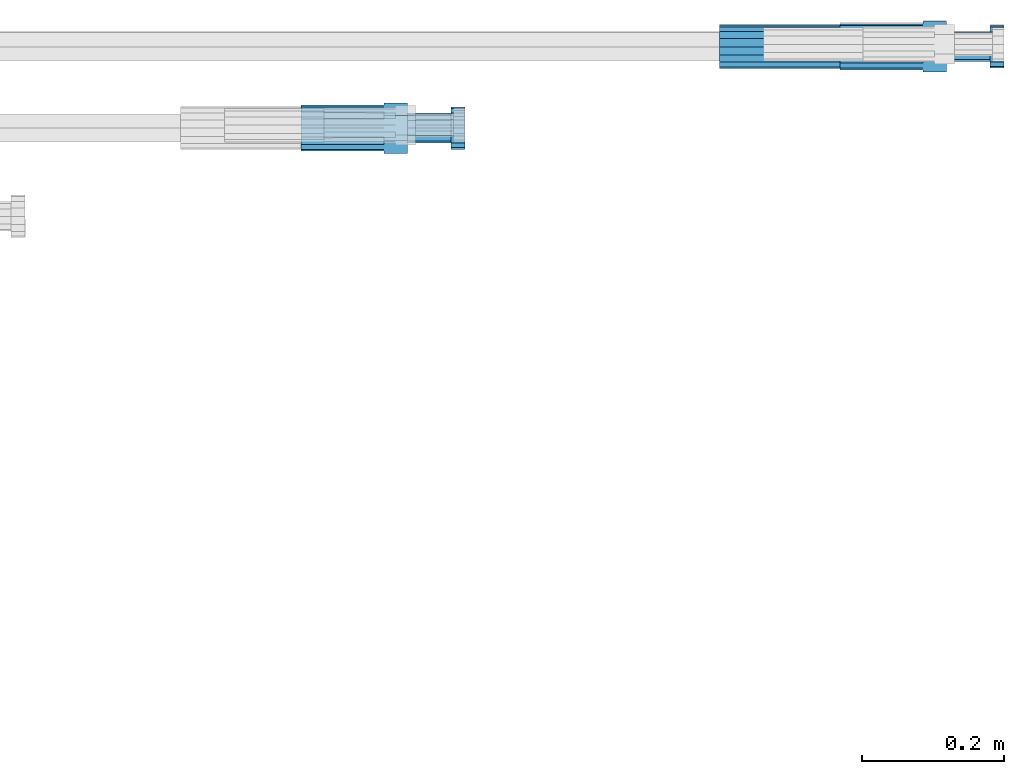
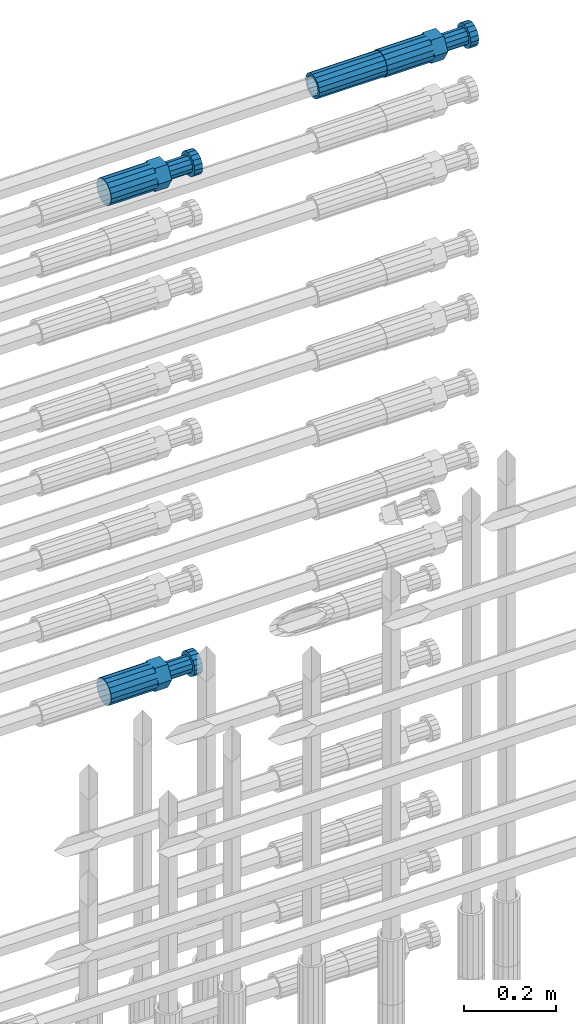
# One storey, part 114 of 119: 4 beams.
"""IFC2X3 building model written with IfcOpenShell, lengths in millimetres."""

from ifc_helpers import new_model, si_unit, frame, origin_with_axes, place, context, subcontext, project, spatial, faceted_brep, material, type_object, element, save


model = new_model("IFC2X3")

# Units and contexts
model_context = context("Model", 3, precision=1e-05, world=origin_with_axes())
body_context = subcontext(model_context, "Body", "Model", "MODEL_VIEW")
ifc_project = project(units=[si_unit("LENGTHUNIT", "METRE", prefix="MILLI"), si_unit("AREAUNIT", "SQUARE_METRE"), si_unit("VOLUMEUNIT", "CUBIC_METRE"), si_unit("MASSUNIT", "GRAM", prefix="KILO"), si_unit("TIMEUNIT", "SECOND"), si_unit("PLANEANGLEUNIT", "RADIAN"), si_unit("SOLIDANGLEUNIT", "STERADIAN"), si_unit("THERMODYNAMICTEMPERATUREUNIT", "DEGREE_CELSIUS"), si_unit("LUMINOUSINTENSITYUNIT", "LUMEN")], contexts=[model_context])

# Site, building, storey
site_placement = place(None, origin_with_axes())
site = spatial("IfcSite", under=ifc_project, at=site_placement, CompositionType="ELEMENT")
building_placement = place(site_placement, origin_with_axes())
building = spatial("IfcBuilding", under=site, at=building_placement, Name="Undefined", CompositionType="ELEMENT")
storey_placement = place(building_placement, origin_with_axes())
storey = spatial("IfcBuildingStorey", under=building, at=storey_placement, Name="Undefined", CompositionType="ELEMENT", Elevation=0.0)

# Beams
ifc_material = material(Name="STEEL/S275")
beam_type_1 = type_object("IfcBeamType", PredefinedType="NOTDEFINED")
beam_1_placement = place(storey_placement, frame((2039349.03023304, 6206399.98994599, 22359.9894122711), z_axis=(0.0, 0.0, 1.0), x_axis=(1.0, 0.0, 0.0)))
element("IfcBeam", 1, at=beam_1_placement, inside=storey, type_object=beam_type_1, material=ifc_material, Name="AG40N", context=body_context, shape_type="Brep", body=[
    faceted_brep([(1.62981450557709e-09, -23.4999999990687, 0.0), (7.45058059692383e-09, -21.7111690142192, 8.99306066057534), (170.000002125278, -21.711168999318, 8.99306066022245), (170.000002127141, -23.4999999844003, -3.66071617463604e-10), (4.65661287307739e-09, -16.6170093587134, 16.6170093578889), (170.000002122484, -16.6170093440451, 16.6170093575288), (1.86264514923096e-09, -8.99306066217832, 21.7111690140277), (170.000002118759, -8.99306064750999, 21.7111690136603), (2.3283064365387e-10, 9.31322574615479e-10, 23.5), (170.000002114102, 1.28056854009628e-08, 23.4999999996485), (-6.51925802230835e-09, 8.99306065868586, 21.7111690140241), (170.00000211224, 8.99306067335419, 21.7111690136639), (-7.45058059692383e-09, 16.6170093561523, 16.6170093578853), (170.000002109446, 16.6170093708206, 16.6170093575324), (-9.31322574615479e-09, 21.711169013055, 8.99306066057534), (170.000002108514, 21.7111690277234, 8.99306066022245), (-1.16415321826935e-09, 23.5000000009313, 0.0), (170.000002108514, 23.5000000144355, -3.66071617463604e-10), (-8.38190317153931e-09, 21.7111690151505, -8.99306066059444), (170.000002110377, 21.7111690300517, -8.9930606609546), (-5.58793544769287e-09, 16.6170093598776, -16.6170093579008), (170.000002113171, 16.6170093745459, -16.6170093582609), (-9.31322574615479e-10, 8.99306066334248, -21.7111690140396), (170.000002115965, 8.99306067801081, -21.7111690143961), (2.3283064365387e-10, 9.31322574615479e-10, -23.5), (170.00000211969, 1.7927959561348e-08, -23.5000000003843), (5.58793544769287e-09, -8.99306065752171, -21.7111690140396), (170.000002123415, -8.99306064285338, -21.7111690143961), (8.38190317153931e-09, -16.6170093549881, -16.6170093579008), (170.000002125278, -16.6170093403198, -16.6170093582646), (9.31322574615479e-09, -21.7111690121237, -8.99306066059444), (170.000002127141, -21.7111689972226, -8.9930606609546), (1.11758708953857e-08, -30.4999999990687, -9.54969436861575e-12), (1.30385160446167e-08, -28.1783257392235, -11.6718446871514), (170.000002129003, -28.1783257243223, -11.6718446875116), (170.000002129935, -30.4999999841675, -3.66071617463604e-10), (1.02445483207703e-08, -21.5667568228673, -21.5667568262129), (170.000002128072, -21.566756808199, -21.5667568265694), (7.45058059692383e-09, -11.6718446831219, -28.1783257416196), (170.000002125278, -11.6718446684536, -28.1783257419834), (3.72529029846191e-09, 3.95812094211578e-09, -30.5000000000277), (170.00000211969, 1.83936208486557e-08, -30.5000000003879), (-9.31322574615479e-10, 11.6718446905725, -28.1783257416232), (170.000002115965, 11.6718447052408, -28.1783257419797), (-6.51925802230835e-09, 21.5667568286881, -21.5667568262093), (170.000002110377, 21.5667568433564, -21.5667568265694), (-9.31322574615479e-09, 28.178325742716, -11.6718446871478), (170.000002108514, 28.1783257573843, -11.6718446875079), (-1.21071934700012e-08, 30.5, -5.91171556152403e-12), (170.000002106652, 30.5000000144355, -3.62433638656512e-10), (-1.21071934700012e-08, 28.1783257401548, 11.6718446871359), (170.00000210572, 28.1783257548232, 11.6718446867794), (-1.02445483207703e-08, 21.5667568240315, 21.5667568261974), (170.000002107583, 21.566756838467, 21.5667568258409), (-7.45058059692383e-09, 11.671844684286, 28.1783257416041), (170.000002110377, 11.6718446989544, 28.178325741244), (-2.79396772384644e-09, -2.56113708019257e-09, 30.5000000000159), (170.000002114102, 1.18743628263474e-08, 30.4999999996558), (1.86264514923096e-09, -11.6718446896411, 28.1783257416114), (170.000002118759, -11.67184467474, 28.178325741244), (7.45058059692383e-09, -21.5667568275239, 21.5667568261974), (170.000002123415, -21.5667568126228, 21.5667568258373), (1.02445483207703e-08, -28.1783257415518, 11.6718446871359), (170.000002127141, -28.1783257271163, 11.6718446867794)], [[[0, 1, 2, 3]], [[1, 4, 5, 2]], [[4, 6, 7, 5]], [[6, 8, 9, 7]], [[8, 10, 11, 9]], [[10, 12, 13, 11]], [[12, 14, 15, 13]], [[14, 16, 17, 15]], [[16, 18, 19, 17]], [[18, 20, 21, 19]], [[20, 22, 23, 21]], [[22, 24, 25, 23]], [[24, 26, 27, 25]], [[26, 28, 29, 27]], [[28, 30, 31, 29]], [[30, 0, 3, 31]], [[32, 33, 34, 35]], [[33, 36, 37, 34]], [[36, 38, 39, 37]], [[38, 40, 41, 39]], [[40, 42, 43, 41]], [[42, 44, 45, 43]], [[44, 46, 47, 45]], [[46, 48, 49, 47]], [[48, 50, 51, 49]], [[50, 52, 53, 51]], [[52, 54, 55, 53]], [[54, 56, 57, 55]], [[56, 58, 59, 57]], [[58, 60, 61, 59]], [[60, 62, 63, 61]], [[62, 32, 35, 63]], [[37, 39, 41, 43, 45, 47, 49, 51, 53, 55, 57, 59, 61, 63, 35, 34], [5, 7, 9, 11, 13, 15, 17, 19, 21, 23, 25, 27, 29, 31, 3, 2]], [[62, 60, 58, 56, 54, 52, 50, 48, 46, 44, 42, 40, 38, 36, 33, 32], [30, 28, 26, 24, 22, 20, 18, 16, 14, 12, 10, 8, 6, 4, 1, 0]]]),
])
beam_type_2 = type_object("IfcBeamType", Name="ROD65", PredefinedType="NOTDEFINED")
beam_2_placement = place(storey_placement, frame((2038759.02023304, 6206285.48994599, 21026.9894209215), z_axis=(0.0, 0.0, 1.0), x_axis=(1.0, 0.0, 0.0)))
element("IfcBeam", 2, at=beam_2_placement, inside=storey, type_object=beam_type_2, material=ifc_material, Name="AGB40", ObjectType="ROD65", context=body_context, shape_type="Brep", body=[
    faceted_brep([(116.999999999069, 17.8249999252148, 30.8738056446964), (116.999999998137, 22.0056957420893, 23.632628078838), (116.999999999069, 12.4372115600854, 30.0260848066173), (116.999999999069, 8.17543111252598, 30.8738056446964), (117.000000000931, -17.8250000746921, 30.8738056446964), (150.200000001118, -17.8250000723638, 30.8738056446964), (150.199999999255, 17.8249999275431, 30.8738056446964), (117.000000000931, -8.17543109622784, 30.8738056446964), (117.000000001863, -22.0056959956419, 23.6326278985034), (117.000000000931, -12.4372115437873, 30.0260848066173), (117.000000001863, -35.6500000746455, -2.18278728425503e-10), (150.200000002049, -35.6500000723172, -2.18278728425503e-10), (117.000000001863, -30.8443149488885, 8.32369080289209), (117.000000001863, -30.8443149488885, -8.32369080355784), (117.000000002794, -32.4999999918509, 0.0), (117.000000000931, -17.8250000746921, -30.873805645133), (150.200000001118, -17.8250000723638, -30.873805645133), (117.000000001863, -22.0056959961075, -23.6326278982269), (117.000000000931, -8.17543109389953, -30.873805645133), (117.000000000931, -12.4372115437873, -30.0260848066173), (116.999999999069, 17.8249999252148, -30.873805645133), (150.199999999255, 17.8249999275431, -30.873805645133), (116.999999999069, 8.17543111019768, -30.873805645133), (116.999999999069, 12.4372115600854, -30.0260848066173), (116.999999998137, 22.005695742555, -23.6326280785652), (116.999999998137, 35.6499999251682, -2.18278728425503e-10), (150.199999998324, 35.6499999277294, -2.18278728425503e-10), (116.999999998137, 30.8443150522653, -8.32369036550881), (116.999999997206, 32.5000000081491, 0.0), (116.999999998137, 30.8443150522653, 8.32369036483942), (1.86264514923096e-09, -22.9809703885112, 22.9809703885621), (1.86264514923096e-09, -30.0260848065373, 12.4372115518672), (117.000000001863, -30.0260847983882, 12.4372115518672), (117.000000001863, -22.9809703803621, 22.9809703885621), (-1.86264514923096e-09, 22.9809703885112, -22.9809703885621), (-1.86264514923096e-09, 30.0260848065373, -12.4372115518672), (116.999999998137, 30.0260848146863, -12.4372115518672), (116.999999998137, 22.9809703966603, -22.9809703885621), (1.86264514923096e-09, -30.0260848065373, -12.4372115518672), (1.86264514923096e-09, -22.9809703885112, -22.9809703885621), (117.000000001863, -22.9809703803621, -22.9809703885621), (117.000000001863, -30.0260847983882, -12.4372115518672), (9.31322574615479e-10, -12.4372115519363, 30.0260848066173), (0.0, 0.0, 32.5), (-9.31322574615479e-10, 12.4372115519363, 30.0260848066173), (-1.86264514923096e-09, 22.9809703885112, 22.9809703885621), (-1.86264514923096e-09, 30.0260848065373, 12.4372115518672), (-2.79396772384644e-09, 32.5, 0.0), (-9.31322574615479e-10, 12.4372115519363, -30.0260848066173), (0.0, 0.0, -32.5), (9.31322574615479e-10, -12.4372115519363, -30.0260848066173), (2.79396772384644e-09, -32.5, 0.0), (116.999999998137, 22.9809703966603, 22.9809703885621), (116.999999998137, 30.0260848146863, 12.4372115518672), (117.0, 8.14907252788544e-09, -32.5), (117.0, 8.14907252788544e-09, 32.5), (150.200000000186, -10.5000000959262, 18.1865334791873), (150.199999999255, -9.59262251853943e-08, 20.9999999997126), (150.199999998324, 10.4999999040738, 18.1865334791873), (150.199999997392, 18.1865333835594, 10.4999999997126), (150.199999997392, 20.9999999040738, -2.87400325760245e-10), (150.199999997392, 18.1865333835594, -10.5000000002874), (150.199999998324, 10.4999999040738, -18.1865334797621), (150.199999999255, -9.59262251853943e-08, -21.0000000002874), (150.200000000186, -10.5000000959262, -18.1865334797621), (150.200000000186, -18.1865335754119, -10.5000000002874), (150.200000001118, -21.0000000959262, -2.87400325760245e-10), (150.200000000186, -18.1865335754119, 10.4999999997126), (210.979999999516, 10.4999999082647, 18.1865334791873), (210.979999999516, -9.17352735996246e-08, 20.9999999997126), (210.979999997653, 18.1865333877504, 10.4999999997126), (210.979999997653, 20.9999999082647, -2.87400325760245e-10), (210.979999997653, 18.1865333877504, -10.5000000002874), (210.979999999516, 10.4999999082647, -18.1865334797621), (210.979999999516, -9.17352735996246e-08, -21.0000000002874), (210.979999999516, -10.5000000917353, -18.1865334797621), (210.980000000447, -18.1865335712209, -10.5000000002874), (210.980000001378, -21.0000000917353, -2.87400325760245e-10), (210.980000000447, -18.1865335712209, 10.4999999997126), (210.979999999516, -10.5000000917353, 18.1865334791873), (211.001368402503, -27.7269939335529, -11.4911163272045), (211.003082515672, -21.2238095656503, -21.2238154190527), (231.002518340945, -21.2131946226582, -21.2132004554769), (231.000804228708, -27.7163789905608, -11.4805013636287), (211.001368415542, -11.4911086384673, -27.7269970399575), (231.000804241747, -11.4804936954752, -27.7163820763781), (210.996487061493, -0.0106066407170147, -30.0106107396168), (230.995922887698, 8.30227509140968e-06, -29.999995776041), (210.98918159306, 11.4698940692469, -27.7269970332745), (230.988617419265, 11.4805090120062, -27.7163820696951), (210.980564201251, 21.2025913291145, -21.2238154067054), (230.980000027455, 21.2132062721066, -21.2132004431296), (210.971946807578, 27.7057702087332, -11.4911163110701), (230.971382633783, 27.7163851517253, -11.4805013474943), (210.964641331695, 29.9893806746695, -0.0106149565435771), (230.9640771579, 29.9999956176616, 7.03221303410828e-09), (210.959759964608, 27.7057637346443, 11.4698863966551), (230.959195790812, 27.7163786776364, 11.4805013602345), (210.958045851439, 21.2025793667417, 21.2025854885032), (230.957481677644, 21.2131943097338, 21.2132004520827), (210.959759951569, 11.4698784395587, 27.705767109408), (230.959195776843, 11.4804933823179, 27.7163820729838), (210.964641305618, -0.0106235581915826, 29.9893808090674), (230.964077131823, -8.61519947648048e-06, 29.9999957726432), (210.971946774051, -11.4911242681555, 27.7057671027251), (230.971382599324, -11.4805093251634, 27.7163820663009), (210.98056416586, -21.2238215280231, 21.2025854761559), (230.979999991134, -21.2132065852638, 21.2132004397354), (210.989181559533, -27.7270004076418, 11.4698863805206), (230.988617384806, -27.7163854646496, 11.4805013441), (210.996487035416, -30.0106108735781, -0.0106149740058754), (230.995922861621, -29.999995930586, -1.04300852399319e-08)], [[[0, 1, 2, 3]], [[4, 5, 6, 0, 3, 7]], [[8, 4, 7, 9]], [[10, 11, 5, 4, 8, 12]], [[13, 10, 12, 14]], [[15, 16, 11, 10, 13, 17]], [[18, 15, 17, 19]], [[20, 21, 16, 15, 18, 22]], [[20, 22, 23, 24]], [[25, 26, 21, 20, 24, 27]], [[25, 27, 28, 29]], [[30, 31, 32, 33]], [[34, 35, 36, 37]], [[38, 39, 40, 41]], [[31, 30, 42, 43, 44, 45, 46, 47, 35, 34, 48, 49, 50, 39, 38, 51]], [[46, 45, 52, 53]], [[28, 47, 46, 53, 29]], [[27, 36, 35, 47, 28]], [[24, 37, 36, 27]], [[23, 48, 34, 37, 24]], [[22, 54, 49, 48, 23]], [[18, 54, 22]], [[19, 50, 49, 54, 18]], [[17, 40, 39, 50, 19]], [[13, 41, 40, 17]], [[14, 51, 38, 41, 13]], [[12, 32, 31, 51, 14]], [[8, 33, 32, 12]], [[9, 42, 30, 33, 8]], [[7, 55, 43, 42, 9]], [[3, 55, 7]], [[2, 44, 43, 55, 3]], [[1, 52, 45, 44, 2]], [[29, 53, 52, 1]], [[0, 6, 26, 25, 29, 1]], [[5, 11, 16, 21, 26, 6], [56, 57, 58, 59, 60, 61, 62, 63, 64, 65, 66, 67]], [[68, 58, 57, 69]], [[70, 59, 58, 68]], [[71, 60, 59, 70]], [[72, 61, 60, 71]], [[73, 62, 61, 72]], [[74, 63, 62, 73]], [[75, 64, 63, 74]], [[76, 65, 64, 75]], [[77, 66, 65, 76]], [[78, 67, 66, 77]], [[79, 56, 67, 78]], [[69, 57, 56, 79]], [[80, 81, 82, 83]], [[81, 84, 85, 82]], [[84, 86, 87, 85]], [[86, 88, 89, 87]], [[88, 90, 91, 89]], [[90, 92, 93, 91]], [[92, 94, 95, 93]], [[94, 96, 97, 95]], [[96, 98, 99, 97]], [[98, 100, 101, 99]], [[100, 102, 103, 101]], [[102, 104, 105, 103]], [[104, 106, 107, 105]], [[106, 108, 109, 107]], [[108, 110, 111, 109]], [[82, 85, 87, 89, 91, 93, 95, 97, 99, 101, 103, 105, 107, 109, 111, 83]], [[110, 80, 83, 111]], [[108, 106, 104, 102, 100, 98, 96, 94, 92, 90, 88, 86, 84, 81, 80, 110], [78, 77, 76, 75, 74, 73, 72, 71, 70, 68, 69, 79]]]),
])
beam_3_placement = place(storey_placement, frame((2038759.02023304, 6206285.48994599, 22354.9894209215), z_axis=(0.0, 0.0, 1.0), x_axis=(1.0, 0.0, 0.0)))
element("IfcBeam", 3, at=beam_3_placement, inside=storey, type_object=beam_type_2, material=ifc_material, Name="AGB40", ObjectType="ROD65", context=body_context, shape_type="Brep", body=[
    faceted_brep([(116.999999999069, 17.8249999252148, 30.8738056446964), (116.999999998137, 22.0056957420893, 23.632628078838), (116.999999999069, 12.4372115600854, 30.0260848066173), (116.999999999069, 8.17543111252598, 30.8738056446964), (117.000000000931, -17.8250000746921, 30.8738056446964), (150.200000001118, -17.8250000723638, 30.8738056446964), (150.199999999255, 17.8249999275431, 30.8738056446964), (117.000000000931, -8.17543109622784, 30.8738056446964), (117.000000001863, -22.0056959956419, 23.6326278985034), (117.000000000931, -12.4372115437873, 30.0260848066173), (117.000000001863, -35.6500000746455, -2.18278728425503e-10), (150.200000002049, -35.6500000723172, -2.18278728425503e-10), (117.000000001863, -30.8443149488885, 8.32369080289209), (117.000000001863, -30.8443149488885, -8.32369080355784), (117.000000002794, -32.4999999918509, 0.0), (117.000000000931, -17.8250000746921, -30.873805645133), (150.200000001118, -17.8250000723638, -30.873805645133), (117.000000001863, -22.0056959961075, -23.6326278982269), (117.000000000931, -8.17543109389953, -30.873805645133), (117.000000000931, -12.4372115437873, -30.0260848066173), (116.999999999069, 17.8249999252148, -30.873805645133), (150.199999999255, 17.8249999275431, -30.873805645133), (116.999999999069, 8.17543111019768, -30.873805645133), (116.999999999069, 12.4372115600854, -30.0260848066173), (116.999999998137, 22.005695742555, -23.6326280785652), (116.999999998137, 35.6499999251682, -2.18278728425503e-10), (150.199999998324, 35.6499999277294, -2.18278728425503e-10), (116.999999998137, 30.8443150522653, -8.32369036550881), (116.999999997206, 32.5000000081491, 0.0), (116.999999998137, 30.8443150522653, 8.32369036483942), (1.86264514923096e-09, -22.9809703885112, 22.9809703885621), (1.86264514923096e-09, -30.0260848065373, 12.4372115518672), (117.000000001863, -30.0260847983882, 12.4372115518672), (117.000000001863, -22.9809703803621, 22.9809703885621), (-1.86264514923096e-09, 22.9809703885112, -22.9809703885621), (-1.86264514923096e-09, 30.0260848065373, -12.4372115518672), (116.999999998137, 30.0260848146863, -12.4372115518672), (116.999999998137, 22.9809703966603, -22.9809703885621), (1.86264514923096e-09, -30.0260848065373, -12.4372115518672), (1.86264514923096e-09, -22.9809703885112, -22.9809703885621), (117.000000001863, -22.9809703803621, -22.9809703885621), (117.000000001863, -30.0260847983882, -12.4372115518672), (9.31322574615479e-10, -12.4372115519363, 30.0260848066173), (0.0, 0.0, 32.5), (-9.31322574615479e-10, 12.4372115519363, 30.0260848066173), (-1.86264514923096e-09, 22.9809703885112, 22.9809703885621), (-1.86264514923096e-09, 30.0260848065373, 12.4372115518672), (-2.79396772384644e-09, 32.5, 0.0), (-9.31322574615479e-10, 12.4372115519363, -30.0260848066173), (0.0, 0.0, -32.5), (9.31322574615479e-10, -12.4372115519363, -30.0260848066173), (2.79396772384644e-09, -32.5, 0.0), (116.999999998137, 22.9809703966603, 22.9809703885621), (116.999999998137, 30.0260848146863, 12.4372115518672), (117.0, 8.14907252788544e-09, -32.5), (117.0, 8.14907252788544e-09, 32.5), (150.200000000186, -10.5000000959262, 18.1865334791873), (150.199999999255, -9.59262251853943e-08, 20.9999999997126), (150.199999998324, 10.4999999040738, 18.1865334791873), (150.199999997392, 18.1865333835594, 10.4999999997126), (150.199999997392, 20.9999999040738, -2.87400325760245e-10), (150.199999997392, 18.1865333835594, -10.5000000002874), (150.199999998324, 10.4999999040738, -18.1865334797621), (150.199999999255, -9.59262251853943e-08, -21.0000000002874), (150.200000000186, -10.5000000959262, -18.1865334797621), (150.200000000186, -18.1865335754119, -10.5000000002874), (150.200000001118, -21.0000000959262, -2.87400325760245e-10), (150.200000000186, -18.1865335754119, 10.4999999997126), (210.979999999516, 10.4999999082647, 18.1865334791873), (210.979999999516, -9.17352735996246e-08, 20.9999999997126), (210.979999997653, 18.1865333877504, 10.4999999997126), (210.979999997653, 20.9999999082647, -2.87400325760245e-10), (210.979999997653, 18.1865333877504, -10.5000000002874), (210.979999999516, 10.4999999082647, -18.1865334797621), (210.979999999516, -9.17352735996246e-08, -21.0000000002874), (210.979999999516, -10.5000000917353, -18.1865334797621), (210.980000000447, -18.1865335712209, -10.5000000002874), (210.980000001378, -21.0000000917353, -2.87400325760245e-10), (210.980000000447, -18.1865335712209, 10.4999999997126), (210.979999999516, -10.5000000917353, 18.1865334791873), (211.001368402503, -27.7269939335529, -11.4911163272045), (211.003082515672, -21.2238095656503, -21.2238154190527), (231.002518340945, -21.2131946226582, -21.2132004554769), (231.000804228708, -27.7163789905608, -11.4805013636287), (211.001368415542, -11.4911086384673, -27.7269970399575), (231.000804241747, -11.4804936954752, -27.7163820763781), (210.996487061493, -0.0106066407170147, -30.0106107396168), (230.995922887698, 8.30227509140968e-06, -29.999995776041), (210.98918159306, 11.4698940692469, -27.7269970332745), (230.988617419265, 11.4805090120062, -27.7163820696951), (210.980564201251, 21.2025913291145, -21.2238154067054), (230.980000027455, 21.2132062721066, -21.2132004431296), (210.971946807578, 27.7057702087332, -11.4911163110701), (230.971382633783, 27.7163851517253, -11.4805013474943), (210.964641331695, 29.9893806746695, -0.0106149565435771), (230.9640771579, 29.9999956176616, 7.03221303410828e-09), (210.959759964608, 27.7057637346443, 11.4698863966551), (230.959195790812, 27.7163786776364, 11.4805013602345), (210.958045851439, 21.2025793667417, 21.2025854885032), (230.957481677644, 21.2131943097338, 21.2132004520827), (210.959759951569, 11.4698784395587, 27.705767109408), (230.959195776843, 11.4804933823179, 27.7163820729838), (210.964641305618, -0.0106235581915826, 29.9893808090674), (230.964077131823, -8.61519947648048e-06, 29.9999957726432), (210.971946774051, -11.4911242681555, 27.7057671027251), (230.971382599324, -11.4805093251634, 27.7163820663009), (210.98056416586, -21.2238215280231, 21.2025854761559), (230.979999991134, -21.2132065852638, 21.2132004397354), (210.989181559533, -27.7270004076418, 11.4698863805206), (230.988617384806, -27.7163854646496, 11.4805013441), (210.996487035416, -30.0106108735781, -0.0106149740058754), (230.995922861621, -29.999995930586, -1.04300852399319e-08)], [[[0, 1, 2, 3]], [[4, 5, 6, 0, 3, 7]], [[8, 4, 7, 9]], [[10, 11, 5, 4, 8, 12]], [[13, 10, 12, 14]], [[15, 16, 11, 10, 13, 17]], [[18, 15, 17, 19]], [[20, 21, 16, 15, 18, 22]], [[20, 22, 23, 24]], [[25, 26, 21, 20, 24, 27]], [[25, 27, 28, 29]], [[30, 31, 32, 33]], [[34, 35, 36, 37]], [[38, 39, 40, 41]], [[31, 30, 42, 43, 44, 45, 46, 47, 35, 34, 48, 49, 50, 39, 38, 51]], [[46, 45, 52, 53]], [[28, 47, 46, 53, 29]], [[27, 36, 35, 47, 28]], [[24, 37, 36, 27]], [[23, 48, 34, 37, 24]], [[22, 54, 49, 48, 23]], [[18, 54, 22]], [[19, 50, 49, 54, 18]], [[17, 40, 39, 50, 19]], [[13, 41, 40, 17]], [[14, 51, 38, 41, 13]], [[12, 32, 31, 51, 14]], [[8, 33, 32, 12]], [[9, 42, 30, 33, 8]], [[7, 55, 43, 42, 9]], [[3, 55, 7]], [[2, 44, 43, 55, 3]], [[1, 52, 45, 44, 2]], [[29, 53, 52, 1]], [[0, 6, 26, 25, 29, 1]], [[5, 11, 16, 21, 26, 6], [56, 57, 58, 59, 60, 61, 62, 63, 64, 65, 66, 67]], [[68, 58, 57, 69]], [[70, 59, 58, 68]], [[71, 60, 59, 70]], [[72, 61, 60, 71]], [[73, 62, 61, 72]], [[74, 63, 62, 73]], [[75, 64, 63, 74]], [[76, 65, 64, 75]], [[77, 66, 65, 76]], [[78, 67, 66, 77]], [[79, 56, 67, 78]], [[69, 57, 56, 79]], [[80, 81, 82, 83]], [[81, 84, 85, 82]], [[84, 86, 87, 85]], [[86, 88, 89, 87]], [[88, 90, 91, 89]], [[90, 92, 93, 91]], [[92, 94, 95, 93]], [[94, 96, 97, 95]], [[96, 98, 99, 97]], [[98, 100, 101, 99]], [[100, 102, 103, 101]], [[102, 104, 105, 103]], [[104, 106, 107, 105]], [[106, 108, 109, 107]], [[108, 110, 111, 109]], [[82, 85, 87, 89, 91, 93, 95, 97, 99, 101, 103, 105, 107, 109, 111, 83]], [[110, 80, 83, 111]], [[108, 106, 104, 102, 100, 98, 96, 94, 92, 90, 88, 86, 84, 81, 80, 110], [78, 77, 76, 75, 74, 73, 72, 71, 70, 68, 69, 79]]]),
])
beam_4_placement = place(storey_placement, frame((2039519.03023304, 6206399.98994599, 22359.9894143674), z_axis=(0.0, 0.0, 1.0), x_axis=(1.0, 0.0, 0.0)))
element("IfcBeam", 4, at=beam_4_placement, inside=storey, type_object=beam_type_2, material=ifc_material, Name="AGB40", ObjectType="ROD65", context=body_context, shape_type="Brep", body=[
    faceted_brep([(116.999999999069, 17.8249999252148, 30.8738056446964), (116.999999998137, 22.0056957420893, 23.632628078838), (116.999999999069, 12.4372115600854, 30.0260848066173), (116.999999999069, 8.17543111252598, 30.8738056446964), (117.000000000931, -17.8250000746921, 30.8738056446964), (150.200000001118, -17.8250000723638, 30.8738056446964), (150.199999999255, 17.8249999275431, 30.8738056446964), (117.000000000931, -8.17543109622784, 30.8738056446964), (117.000000001863, -22.0056959956419, 23.6326278985034), (117.000000000931, -12.4372115437873, 30.0260848066173), (117.000000001863, -35.6500000746455, -2.18278728425503e-10), (150.200000002049, -35.6500000723172, -2.18278728425503e-10), (117.000000001863, -30.8443149488885, 8.32369080289209), (117.000000001863, -30.8443149488885, -8.32369080355784), (117.000000002794, -32.4999999918509, 0.0), (117.000000000931, -17.8250000746921, -30.873805645133), (150.200000001118, -17.8250000723638, -30.873805645133), (117.000000001863, -22.0056959961075, -23.6326278982269), (117.000000000931, -8.17543109389953, -30.873805645133), (117.000000000931, -12.4372115437873, -30.0260848066173), (116.999999999069, 17.8249999252148, -30.873805645133), (150.199999999255, 17.8249999275431, -30.873805645133), (116.999999999069, 8.17543111019768, -30.873805645133), (116.999999999069, 12.4372115600854, -30.0260848066173), (116.999999998137, 22.005695742555, -23.6326280785652), (116.999999998137, 35.6499999251682, -2.18278728425503e-10), (150.199999998324, 35.6499999277294, -2.18278728425503e-10), (116.999999998137, 30.8443150522653, -8.32369036550881), (116.999999997206, 32.5000000081491, 0.0), (116.999999998137, 30.8443150522653, 8.32369036483942), (1.86264514923096e-09, -22.9809703885112, 22.9809703885621), (1.86264514923096e-09, -30.0260848065373, 12.4372115518672), (117.000000001863, -30.0260847983882, 12.4372115518672), (117.000000001863, -22.9809703803621, 22.9809703885621), (-1.86264514923096e-09, 22.9809703885112, -22.9809703885621), (-1.86264514923096e-09, 30.0260848065373, -12.4372115518672), (116.999999998137, 30.0260848146863, -12.4372115518672), (116.999999998137, 22.9809703966603, -22.9809703885621), (1.86264514923096e-09, -30.0260848065373, -12.4372115518672), (1.86264514923096e-09, -22.9809703885112, -22.9809703885621), (117.000000001863, -22.9809703803621, -22.9809703885621), (117.000000001863, -30.0260847983882, -12.4372115518672), (9.31322574615479e-10, -12.4372115519363, 30.0260848066173), (0.0, 0.0, 32.5), (-9.31322574615479e-10, 12.4372115519363, 30.0260848066173), (-1.86264514923096e-09, 22.9809703885112, 22.9809703885621), (-1.86264514923096e-09, 30.0260848065373, 12.4372115518672), (-2.79396772384644e-09, 32.5, 0.0), (-9.31322574615479e-10, 12.4372115519363, -30.0260848066173), (0.0, 0.0, -32.5), (9.31322574615479e-10, -12.4372115519363, -30.0260848066173), (2.79396772384644e-09, -32.5, 0.0), (116.999999998137, 22.9809703966603, 22.9809703885621), (116.999999998137, 30.0260848146863, 12.4372115518672), (117.0, 8.14907252788544e-09, -32.5), (117.0, 8.14907252788544e-09, 32.5), (150.200000000186, -10.5000000959262, 18.1865334791873), (150.199999999255, -9.59262251853943e-08, 20.9999999997126), (150.199999998324, 10.4999999040738, 18.1865334791873), (150.199999997392, 18.1865333835594, 10.4999999997126), (150.199999997392, 20.9999999040738, -2.87400325760245e-10), (150.199999997392, 18.1865333835594, -10.5000000002874), (150.199999998324, 10.4999999040738, -18.1865334797621), (150.199999999255, -9.59262251853943e-08, -21.0000000002874), (150.200000000186, -10.5000000959262, -18.1865334797621), (150.200000000186, -18.1865335754119, -10.5000000002874), (150.200000001118, -21.0000000959262, -2.87400325760245e-10), (150.200000000186, -18.1865335754119, 10.4999999997126), (210.979999999516, 10.4999999082647, 18.1865334791873), (210.979999999516, -9.17352735996246e-08, 20.9999999997126), (210.979999997653, 18.1865333877504, 10.4999999997126), (210.979999997653, 20.9999999082647, -2.87400325760245e-10), (210.979999997653, 18.1865333877504, -10.5000000002874), (210.979999999516, 10.4999999082647, -18.1865334797621), (210.979999999516, -9.17352735996246e-08, -21.0000000002874), (210.979999999516, -10.5000000917353, -18.1865334797621), (210.980000000447, -18.1865335712209, -10.5000000002874), (210.980000001378, -21.0000000917353, -2.87400325760245e-10), (210.980000000447, -18.1865335712209, 10.4999999997126), (210.979999999516, -10.5000000917353, 18.1865334791873), (211.001368402503, -27.7269939335529, -11.4911163272045), (211.003082515672, -21.2238095656503, -21.2238154190527), (231.002518340945, -21.2131946226582, -21.2132004554769), (231.000804228708, -27.7163789905608, -11.4805013636287), (211.001368415542, -11.4911086384673, -27.7269970399575), (231.000804241747, -11.4804936954752, -27.7163820763781), (210.996487061493, -0.0106066407170147, -30.0106107396168), (230.995922887698, 8.30227509140968e-06, -29.999995776041), (210.98918159306, 11.4698940692469, -27.7269970332745), (230.988617419265, 11.4805090120062, -27.7163820696951), (210.980564201251, 21.2025913291145, -21.2238154067054), (230.980000027455, 21.2132062721066, -21.2132004431296), (210.971946807578, 27.7057702087332, -11.4911163110701), (230.971382633783, 27.7163851517253, -11.4805013474943), (210.964641331695, 29.9893806746695, -0.0106149565435771), (230.9640771579, 29.9999956176616, 7.03221303410828e-09), (210.959759964608, 27.7057637346443, 11.4698863966551), (230.959195790812, 27.7163786776364, 11.4805013602345), (210.958045851439, 21.2025793667417, 21.2025854885032), (230.957481677644, 21.2131943097338, 21.2132004520827), (210.959759951569, 11.4698784395587, 27.705767109408), (230.959195776843, 11.4804933823179, 27.7163820729838), (210.964641305618, -0.0106235581915826, 29.9893808090674), (230.964077131823, -8.61519947648048e-06, 29.9999957726432), (210.971946774051, -11.4911242681555, 27.7057671027251), (230.971382599324, -11.4805093251634, 27.7163820663009), (210.98056416586, -21.2238215280231, 21.2025854761559), (230.979999991134, -21.2132065852638, 21.2132004397354), (210.989181559533, -27.7270004076418, 11.4698863805206), (230.988617384806, -27.7163854646496, 11.4805013441), (210.996487035416, -30.0106108735781, -0.0106149740058754), (230.995922861621, -29.999995930586, -1.04300852399319e-08)], [[[0, 1, 2, 3]], [[4, 5, 6, 0, 3, 7]], [[8, 4, 7, 9]], [[10, 11, 5, 4, 8, 12]], [[13, 10, 12, 14]], [[15, 16, 11, 10, 13, 17]], [[18, 15, 17, 19]], [[20, 21, 16, 15, 18, 22]], [[20, 22, 23, 24]], [[25, 26, 21, 20, 24, 27]], [[25, 27, 28, 29]], [[30, 31, 32, 33]], [[34, 35, 36, 37]], [[38, 39, 40, 41]], [[31, 30, 42, 43, 44, 45, 46, 47, 35, 34, 48, 49, 50, 39, 38, 51]], [[46, 45, 52, 53]], [[28, 47, 46, 53, 29]], [[27, 36, 35, 47, 28]], [[24, 37, 36, 27]], [[23, 48, 34, 37, 24]], [[22, 54, 49, 48, 23]], [[18, 54, 22]], [[19, 50, 49, 54, 18]], [[17, 40, 39, 50, 19]], [[13, 41, 40, 17]], [[14, 51, 38, 41, 13]], [[12, 32, 31, 51, 14]], [[8, 33, 32, 12]], [[9, 42, 30, 33, 8]], [[7, 55, 43, 42, 9]], [[3, 55, 7]], [[2, 44, 43, 55, 3]], [[1, 52, 45, 44, 2]], [[29, 53, 52, 1]], [[0, 6, 26, 25, 29, 1]], [[5, 11, 16, 21, 26, 6], [56, 57, 58, 59, 60, 61, 62, 63, 64, 65, 66, 67]], [[68, 58, 57, 69]], [[70, 59, 58, 68]], [[71, 60, 59, 70]], [[72, 61, 60, 71]], [[73, 62, 61, 72]], [[74, 63, 62, 73]], [[75, 64, 63, 74]], [[76, 65, 64, 75]], [[77, 66, 65, 76]], [[78, 67, 66, 77]], [[79, 56, 67, 78]], [[69, 57, 56, 79]], [[80, 81, 82, 83]], [[81, 84, 85, 82]], [[84, 86, 87, 85]], [[86, 88, 89, 87]], [[88, 90, 91, 89]], [[90, 92, 93, 91]], [[92, 94, 95, 93]], [[94, 96, 97, 95]], [[96, 98, 99, 97]], [[98, 100, 101, 99]], [[100, 102, 103, 101]], [[102, 104, 105, 103]], [[104, 106, 107, 105]], [[106, 108, 109, 107]], [[108, 110, 111, 109]], [[82, 85, 87, 89, 91, 93, 95, 97, 99, 101, 103, 105, 107, 109, 111, 83]], [[110, 80, 83, 111]], [[108, 106, 104, 102, 100, 98, 96, 94, 92, 90, 88, 86, 84, 81, 80, 110], [78, 77, 76, 75, 74, 73, 72, 71, 70, 68, 69, 79]]]),
])

save(model, "model.ifc")
